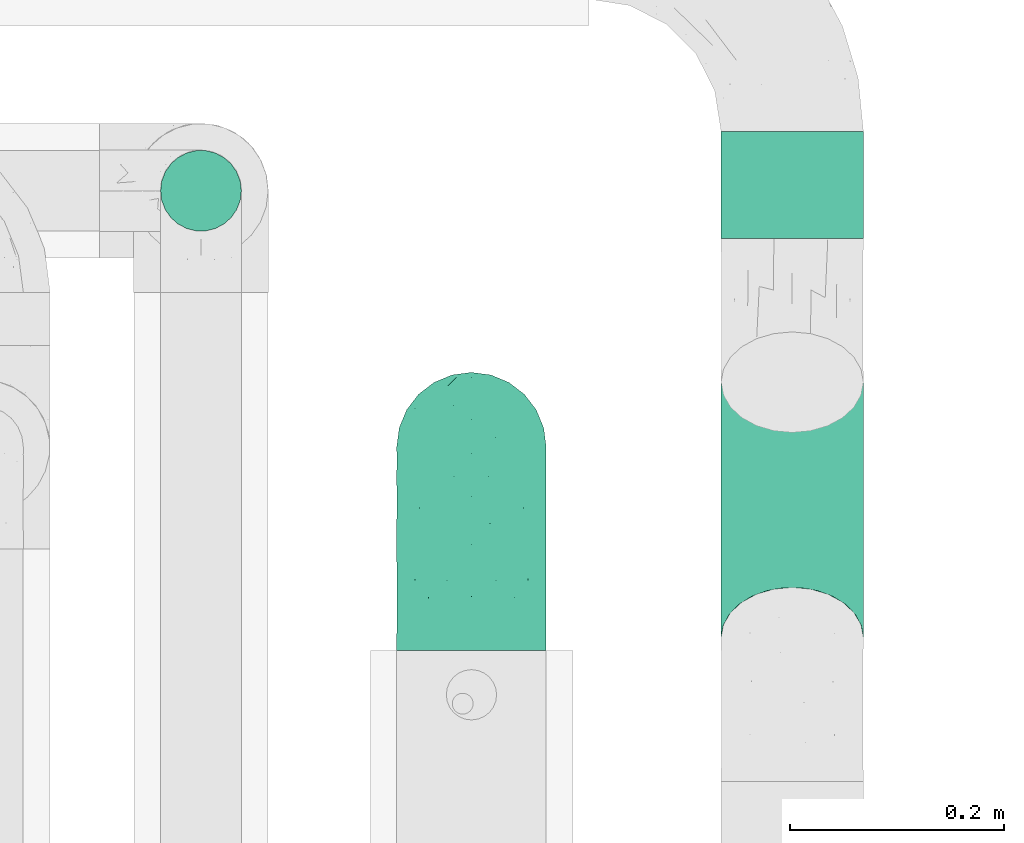
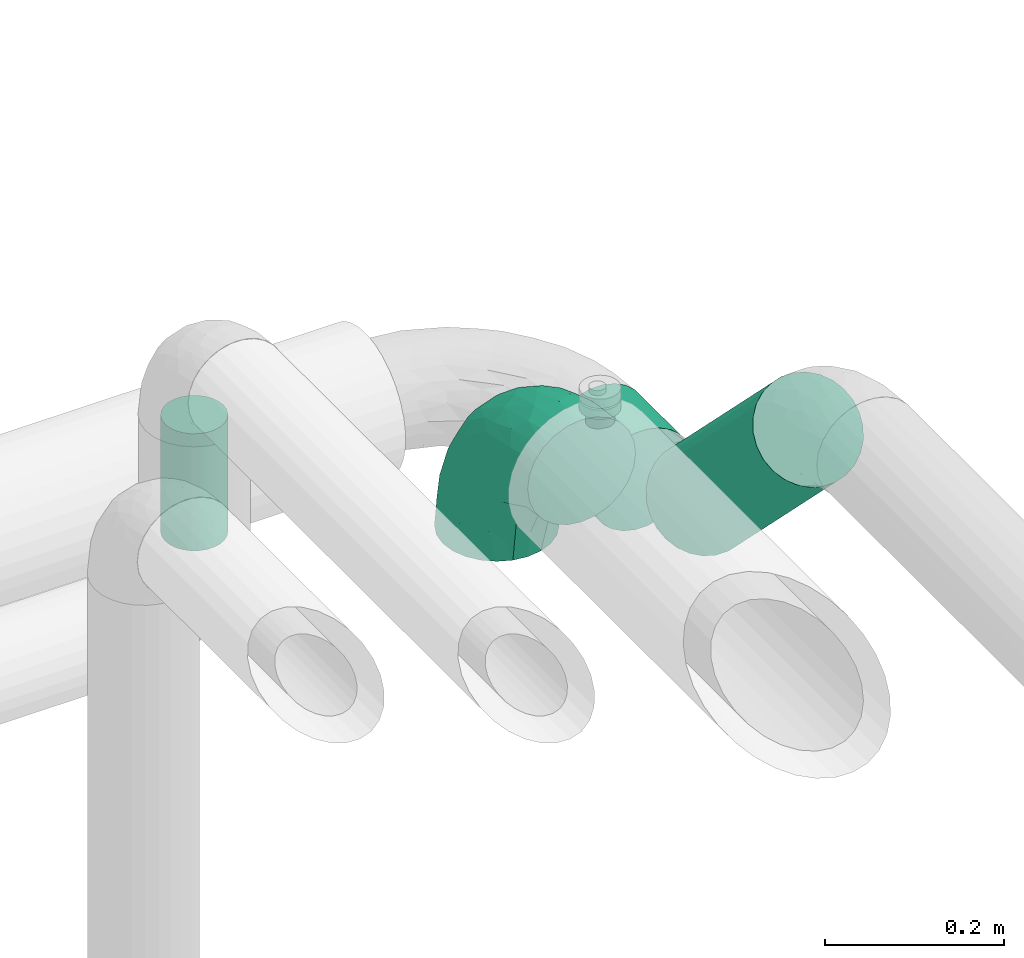
# One storey, part 558 of 824: 3 flow segments, 1 flow fitting.
"""IFC2X3 building model written with IfcOpenShell, lengths in millimetres."""

from ifc_helpers import new_model, entity, si_unit, converted_unit, derived_unit, direction, frame, origin, origin_2d_with_axis, place, context, subcontext, project, spatial, circle, extrude, faceted_brep, source, transform, mapped, material, type_object, type_shapes, element, save


model = new_model("IFC2X3")

# Units and contexts
model_context = context("Model", 3, precision=0.01, world=origin(), true_north=direction((6.12303176911189e-17, 1.0)))
body_context = subcontext(model_context, "Body", "Model", "MODEL_VIEW")
ifc_project = project(units=[si_unit("LENGTHUNIT", "METRE", prefix="MILLI"), si_unit("AREAUNIT", "SQUARE_METRE"), si_unit("VOLUMEUNIT", "CUBIC_METRE"), converted_unit("PLANEANGLEUNIT", "DEGREE", entity("IfcRatioMeasure", 0.0174532925199433), si_unit("PLANEANGLEUNIT", "RADIAN"), dimensions=[0, 0, 0, 0, 0, 0, 0]), si_unit("MASSUNIT", "GRAM", prefix="KILO"), derived_unit("MASSDENSITYUNIT", [(si_unit("MASSUNIT", "GRAM", prefix="KILO"), 1), (si_unit("LENGTHUNIT", "METRE"), -3)]), derived_unit("MOMENTOFINERTIAUNIT", [(si_unit("LENGTHUNIT", "METRE"), 4)]), si_unit("TIMEUNIT", "SECOND"), si_unit("FREQUENCYUNIT", "HERTZ"), si_unit("THERMODYNAMICTEMPERATUREUNIT", "DEGREE_CELSIUS"), derived_unit("THERMALTRANSMITTANCEUNIT", [(si_unit("MASSUNIT", "GRAM", prefix="KILO"), 1), (si_unit("THERMODYNAMICTEMPERATUREUNIT", "KELVIN"), -1), (si_unit("TIMEUNIT", "SECOND"), -3)]), derived_unit("VOLUMETRICFLOWRATEUNIT", [(si_unit("LENGTHUNIT", "METRE"), 3), (si_unit("TIMEUNIT", "SECOND"), -1)]), derived_unit("MASSFLOWRATEUNIT", [(si_unit("MASSUNIT", "GRAM", prefix="KILO"), 1), (si_unit("TIMEUNIT", "SECOND"), -1)]), derived_unit("ROTATIONALFREQUENCYUNIT", [(si_unit("TIMEUNIT", "SECOND"), -1)]), si_unit("ELECTRICCURRENTUNIT", "AMPERE"), si_unit("ELECTRICVOLTAGEUNIT", "VOLT"), si_unit("POWERUNIT", "WATT"), si_unit("FORCEUNIT", "NEWTON", prefix="KILO"), si_unit("ILLUMINANCEUNIT", "LUX"), si_unit("LUMINOUSFLUXUNIT", "LUMEN"), si_unit("LUMINOUSINTENSITYUNIT", "CANDELA"), derived_unit("USERDEFINED", [(si_unit("MASSUNIT", "GRAM", prefix="KILO"), -1), (si_unit("LENGTHUNIT", "METRE"), -2), (si_unit("TIMEUNIT", "SECOND"), 3), (si_unit("LUMINOUSFLUXUNIT", "LUMEN"), 1)]), derived_unit("LINEARVELOCITYUNIT", [(si_unit("LENGTHUNIT", "METRE"), 1), (si_unit("TIMEUNIT", "SECOND"), -1)]), si_unit("PRESSUREUNIT", "PASCAL"), derived_unit("USERDEFINED", [(si_unit("LENGTHUNIT", "METRE"), -2), (si_unit("MASSUNIT", "GRAM", prefix="KILO"), 1), (si_unit("TIMEUNIT", "SECOND"), -2)]), derived_unit("LINEARFORCEUNIT", [(si_unit("MASSUNIT", "GRAM", prefix="KILO"), 1), (si_unit("LENGTHUNIT", "METRE"), 1), (si_unit("TIMEUNIT", "SECOND"), -2), (si_unit("LENGTHUNIT", "METRE"), -1)]), derived_unit("PLANARFORCEUNIT", [(si_unit("MASSUNIT", "GRAM", prefix="KILO"), 1), (si_unit("LENGTHUNIT", "METRE"), 1), (si_unit("TIMEUNIT", "SECOND"), -2), (si_unit("LENGTHUNIT", "METRE"), -2)])], contexts=[model_context])

# Site, building, storey
site_placement = place(None, origin())
site = spatial("IfcSite", under=ifc_project, at=site_placement, CompositionType="ELEMENT")
building_placement = place(site_placement, origin())
building = spatial("IfcBuilding", under=site, at=building_placement, CompositionType="ELEMENT")
storey_placement = place(building_placement, frame((0.0, 0.0, 28200.0)))
storey = spatial("IfcBuildingStorey", under=building, at=storey_placement, CompositionType="ELEMENT", Elevation=28200.0)

# Flow segments
pipe_segment_type_1 = type_object("IfcPipeSegmentType", PredefinedType="NOTDEFINED")
flow_segment_1_placement = place(storey_placement, frame((27351.94, 12025.46, 3031.9)))
element("IfcFlowSegment", 1, at=flow_segment_1_placement, inside=storey, type_object=pipe_segment_type_1, context=body_context, shape_type="SweptSolid", body=[
    extrude(circle(Radius=66.5, at=origin_2d_with_axis()), frame((68.1, 0.0, 68.1), z_axis=(0.0, 1.0, 0.0), x_axis=(-1.0, 0.0, 0.0)), (0.0, 0.0, 1.0), 100.109244825128),
])
flow_segment_2_placement = place(storey_placement, frame((27351.94, 11603.79, 3107.03)))
element("IfcFlowSegment", 2, at=flow_segment_2_placement, inside=storey, type_object=pipe_segment_type_1, context=body_context, shape_type="SweptSolid", body=[
    extrude(circle(Radius=66.5, at=origin_2d_with_axis()), frame((68.1, 48.62, 287.32), z_axis=(0.0, 0.707106781186515, -0.70710678118658), x_axis=(-1.0, 0.0, 0.0)), (0.0, 0.0, 1.0), 337.573593128828),
])
pipe_segment_type_2 = type_object("IfcPipeSegmentType", PredefinedType="NOTDEFINED")
flow_segment_3_placement = place(storey_placement, frame((26828.29, 12030.66, 3195.0)))
element("IfcFlowSegment", 3, at=flow_segment_3_placement, inside=storey, type_object=pipe_segment_type_2, context=body_context, shape_type="SweptSolid", body=[
    extrude(circle(Radius=37.75, at=origin_2d_with_axis()), frame((39.35, 39.35, 0.0), z_axis=(0.0, 0.0, 1.0), x_axis=(-1.0, 0.0, 0.0)), (0.0, 0.0, 1.0), 160.000000000016),
])

# Flow fitting
ifc_material = material()
pipe_fitting_type = type_object("IfcPipeFittingType", PredefinedType="NOTDEFINED", material=ifc_material)
shared_shape = source(origin(), body_context, "Body", "Brep", [
    faceted_brep([(-190.0, 18.08, -67.47), (-190.0, 0.0, -69.85), (-190.0, -18.08, -67.47), (-190.0, -34.93, -60.49), (-190.0, -49.39, -49.39), (-190.0, -60.49, -34.93), (-190.0, -67.47, -18.08), (-190.0, -69.85, 0.0), (-190.0, -67.47, 18.08), (-190.0, -60.49, 34.92), (-190.0, -49.39, 49.39), (-190.0, -34.93, 60.49), (-190.0, -18.08, 67.47), (-190.0, 0.0, 69.85), (-190.0, 18.08, 67.47), (-190.0, 34.92, 60.49), (-190.0, 49.39, 49.39), (-190.0, 60.49, 34.92), (-190.0, 67.47, 18.08), (-190.0, 69.85, 0.0), (-190.0, 67.47, -18.08), (-190.0, 60.49, -34.93), (-190.0, 49.39, -49.39), (-190.0, 34.92, -60.49), (18.08, 190.0, -67.47), (0.0, 190.0, -69.85), (-18.08, 190.0, -67.47), (-34.92, 190.0, -60.49), (-49.39, 190.0, -49.39), (-60.49, 190.0, -34.93), (-67.47, 190.0, -18.08), (-69.85, 190.0, 0.0), (-67.47, 190.0, 18.08), (-60.49, 190.0, 34.92), (-49.39, 190.0, 49.39), (-34.92, 190.0, 60.49), (-18.08, 190.0, 67.47), (0.0, 190.0, 69.85), (18.08, 190.0, 67.47), (34.93, 190.0, 60.49), (49.39, 190.0, 49.39), (60.49, 190.0, 34.92), (67.47, 190.0, 18.08), (69.85, 190.0, 0.0), (67.47, 190.0, -18.08), (60.49, 190.0, -34.93), (49.39, 190.0, -49.39), (34.93, 190.0, -60.49), (-29.62, 146.98, 65.62), (-13.75, 135.37, 69.64), (-124.22, -36.33, 52.83), (-140.23, -52.18, 40.04), (-80.56, -34.09, 36.78), (-140.97, -24.01, 63.29), (-80.93, -8.05, 59.8), (-100.59, 5.62, 68.24), (-125.19, -57.65, 22.9), (-139.31, -64.86, 0.0), (-28.7, -8.91, 22.6), (-45.64, -26.06, 0.0), (-6.26, 6.26, 0.0), (-105.44, 36.89, 68.2), (-118.83, 43.56, 64.34), (-146.98, 29.62, 65.62), (-71.47, -38.86, 17.07), (-90.56, -50.07, 0.0), (-0.6, 27.02, 35.97), (-44.76, -2.31, 47.74), (-42.86, -12.1, 35.78), (-148.03, -7.38, 68.85), (-135.37, 13.75, 69.64), (-67.48, 159.11, 28.79), (36.32, 124.15, 52.82), (-38.8, 102.11, 68.2), (-24.59, 96.61, 69.85), (-81.73, 130.22, 21.92), (-65.15, 30.31, 68.68), (-27.72, 54.52, 66.49), (-44.98, 61.25, 69.74), (-75.73, 152.87, 0.0), (-159.11, 67.48, 28.79), (-130.22, 81.73, 21.92), (-152.87, 75.73, 0.0), (-76.65, 126.59, 35.57), (-101.51, 101.51, 25.92), (-96.74, 96.74, 38.75), (-144.94, 60.97, 45.11), (-159.57, 43.91, 56.71), (-119.38, 92.8, 0.0), (50.07, 90.56, 0.0), (57.42, 124.25, 22.84), (38.8, 71.6, 17.49), (64.86, 139.31, 0.0), (52.17, 140.21, 40.03), (33.37, 79.39, 36.99), (24.0, 140.95, 63.29), (8.03, 80.92, 59.81), (-82.61, -22.17, 50.94), (7.38, 148.03, 68.85), (-100.26, 79.14, 51.33), (-75.76, 96.1, 55.72), (-76.12, 111.95, 46.7), (-92.8, 119.38, 0.0), (-104.27, 104.27, 12.31), (10.07, 27.17, 16.15), (26.06, 45.64, 0.0), (-61.21, 144.14, 45.16), (-44.13, 158.15, 56.77), (-55.26, 120.41, 58.38), (9.95, 57.03, 48.64), (29.48, 90.08, 47.56), (-5.62, 100.59, 68.24), (-122.78, 54.24, 58.28), (-86.25, 73.26, 61.12), (-95.79, 24.47, 69.85), (-126.59, 76.65, 35.57), (-17.15, 26.56, 50.85), (-29.82, 29.82, 59.54), (-70.73, 11.02, 65.19), (-58.6, 94.58, 64.16), (-71.14, 66.1, 67.41), (-158.15, 44.13, -56.77), (33.37, 79.39, -36.99), (10.07, 27.17, -16.15), (-0.6, 27.02, -35.97), (-100.59, 5.62, -68.24), (-148.03, -7.38, -68.85), (-135.37, 13.75, -69.64), (-130.22, 81.73, -21.92), (-146.98, 29.62, -65.62), (-102.11, 38.8, -68.2), (-96.61, 24.59, -69.85), (-83.02, -24.86, -48.76), (-44.76, -2.31, -47.74), (-80.56, -34.09, -36.78), (-122.68, -57.24, -22.15), (-71.43, -38.87, -16.95), (-104.27, 104.27, -12.31), (-159.11, 67.48, -28.79), (-144.14, 61.21, -45.16), (7.38, 148.03, -68.85), (-13.75, 135.37, -69.64), (-79.14, 100.26, -51.33), (-96.1, 75.76, -55.72), (-111.95, 76.12, -46.7), (-80.93, -8.05, -59.8), (-124.22, -36.33, -52.83), (-140.23, -52.18, -40.04), (-24.47, 95.79, -69.85), (-36.89, 105.44, -68.2), (-150.18, -65.36, -13.92), (-43.56, 118.83, -64.34), (-29.62, 146.98, -65.62), (38.8, 71.6, -17.49), (-81.73, 130.22, -21.92), (-28.7, -8.91, -22.6), (-54.24, 122.78, -58.28), (-73.26, 86.25, -61.12), (-61.25, 44.98, -69.74), (-30.31, 65.15, -68.68), (-54.52, 27.72, -66.49), (-101.51, 101.51, -25.92), (-126.59, 76.65, -35.57), (-96.74, 96.74, -38.75), (-67.48, 159.11, -28.79), (-120.41, 55.26, -58.38), (-43.91, 159.57, -56.71), (24.0, 140.95, -63.29), (8.03, 80.92, -59.81), (-5.62, 100.59, -68.24), (-60.97, 144.94, -45.11), (36.32, 124.15, -52.82), (57.42, 124.25, -22.84), (52.17, 140.21, -40.03), (-140.97, -24.01, -63.29), (9.95, 57.03, -48.64), (-76.65, 126.59, -35.57), (22.84, 89.04, -52.94), (-11.03, 70.74, -65.2), (-29.82, 29.82, -59.54), (-94.58, 58.6, -64.16), (-66.1, 71.14, -67.41), (-31.42, -3.01, -36.09), (-13.88, 24.32, -46.86)], [[[0, 1, 2, 3, 4, 5, 6, 7, 8, 9, 10, 11, 12, 13, 14, 15, 16, 17, 18, 19, 20, 21, 22, 23]], [[24, 25, 26, 27, 28, 29, 30, 31, 32, 33, 34, 35, 36, 37, 38, 39, 40, 41, 42, 43, 44, 45, 46, 47]], [[36, 48, 49]], [[50, 51, 52]], [[53, 54, 55]], [[56, 9, 8]], [[8, 7, 57]], [[58, 59, 60]], [[51, 9, 56]], [[61, 62, 63]], [[59, 58, 64]], [[59, 64, 65]], [[11, 10, 50]], [[66, 67, 68]], [[50, 53, 11]], [[69, 70, 13]], [[71, 33, 32]], [[72, 40, 39]], [[73, 74, 49]], [[63, 15, 14]], [[13, 70, 14]], [[71, 32, 75]], [[12, 69, 13]], [[76, 77, 78]], [[32, 79, 75]], [[18, 80, 81]], [[63, 14, 70]], [[82, 19, 18]], [[83, 84, 85]], [[86, 16, 87]], [[82, 81, 88]], [[82, 18, 81]], [[15, 87, 16]], [[83, 71, 75]], [[52, 56, 64]], [[49, 37, 36]], [[89, 90, 91]], [[36, 35, 48]], [[42, 41, 90]], [[89, 92, 90]], [[11, 53, 12]], [[73, 78, 74]], [[65, 56, 57]], [[40, 72, 93]], [[94, 90, 93]], [[41, 40, 93]], [[72, 95, 96]], [[95, 39, 38]], [[8, 57, 56]], [[43, 42, 92]], [[67, 54, 97]], [[38, 37, 98]], [[99, 100, 101]], [[102, 75, 79]], [[51, 10, 9]], [[102, 88, 103]], [[31, 79, 32]], [[104, 60, 105]], [[106, 34, 33]], [[84, 103, 81]], [[91, 105, 89]], [[107, 35, 34]], [[106, 108, 107]], [[49, 48, 73]], [[104, 105, 91]], [[16, 86, 17]], [[58, 104, 66]], [[109, 110, 96]], [[111, 98, 49]], [[112, 113, 99]], [[92, 42, 90]], [[95, 72, 39]], [[70, 114, 61]], [[80, 18, 17]], [[101, 106, 83]], [[99, 86, 112]], [[115, 81, 80]], [[90, 94, 91]], [[94, 66, 104]], [[64, 58, 68]], [[56, 65, 64]], [[93, 72, 110]], [[90, 41, 93]], [[98, 95, 38]], [[111, 77, 96]], [[111, 96, 95]], [[67, 116, 117]], [[52, 51, 56]], [[50, 10, 51]], [[54, 53, 50]], [[69, 53, 55]], [[97, 52, 67]], [[118, 76, 55]], [[107, 48, 35]], [[73, 119, 120]], [[61, 63, 70]], [[63, 62, 87]], [[94, 104, 91]], [[58, 60, 104]], [[109, 66, 94]], [[67, 117, 54]], [[68, 67, 52]], [[116, 66, 109]], [[119, 48, 108]], [[73, 120, 78]], [[120, 61, 114]], [[78, 114, 76]], [[49, 98, 37]], [[95, 98, 111]], [[53, 69, 12]], [[70, 69, 55]], [[70, 55, 114]], [[120, 113, 62]], [[76, 114, 55]], [[120, 114, 78]], [[118, 55, 54]], [[76, 118, 77]], [[96, 77, 117]], [[111, 78, 77]], [[54, 117, 118]], [[77, 118, 117]], [[110, 109, 94]], [[116, 96, 117]], [[106, 107, 34]], [[48, 107, 108]], [[75, 84, 83]], [[106, 33, 71]], [[101, 83, 85]], [[106, 71, 83]], [[99, 101, 85]], [[108, 106, 101]], [[99, 85, 115]], [[113, 112, 62]], [[119, 113, 120]], [[100, 99, 113]], [[17, 86, 80]], [[115, 85, 84]], [[80, 86, 115]], [[99, 115, 86]], [[63, 87, 15]], [[86, 87, 112]], [[78, 111, 74]], [[111, 49, 74]], [[119, 100, 113]], [[101, 100, 108]], [[48, 119, 73]], [[119, 108, 100]], [[75, 102, 103]], [[115, 84, 81]], [[81, 103, 88]], [[75, 103, 84]], [[54, 50, 97]], [[52, 97, 50]], [[64, 68, 52]], [[66, 68, 58]], [[62, 61, 120]], [[87, 62, 112]], [[93, 110, 94]], [[96, 110, 72]], [[66, 116, 67]], [[96, 116, 109]], [[22, 121, 23]], [[122, 123, 124]], [[125, 126, 127]], [[20, 82, 128]], [[129, 130, 127]], [[130, 131, 127]], [[19, 82, 20]], [[132, 133, 134]], [[88, 128, 82]], [[135, 136, 65]], [[102, 137, 88]], [[138, 20, 128]], [[139, 22, 21]], [[140, 141, 25]], [[142, 143, 144]], [[145, 133, 132]], [[4, 146, 147]], [[141, 148, 149]], [[7, 6, 150]], [[138, 21, 20]], [[5, 4, 147]], [[149, 151, 152]], [[59, 65, 136]], [[122, 153, 123]], [[79, 30, 154]], [[134, 155, 136]], [[150, 65, 57]], [[156, 157, 142]], [[126, 2, 1]], [[134, 135, 147]], [[130, 158, 131]], [[159, 160, 158]], [[154, 161, 137]], [[0, 23, 129]], [[127, 1, 0]], [[162, 138, 128]], [[161, 163, 162]], [[30, 79, 31]], [[146, 4, 3]], [[154, 30, 164]], [[152, 27, 26]], [[165, 121, 139]], [[25, 24, 140]], [[25, 141, 26]], [[164, 30, 29]], [[27, 166, 28]], [[167, 168, 169]], [[141, 152, 26]], [[28, 170, 29]], [[47, 171, 167]], [[172, 89, 153]], [[59, 155, 60]], [[28, 166, 170]], [[46, 45, 173]], [[153, 89, 105]], [[105, 123, 153]], [[174, 146, 3]], [[171, 47, 46]], [[45, 44, 172]], [[7, 150, 57]], [[43, 92, 44]], [[122, 124, 175]], [[89, 172, 92]], [[171, 173, 122]], [[47, 167, 24]], [[173, 171, 46]], [[135, 150, 5]], [[0, 129, 127]], [[174, 3, 2]], [[79, 154, 102]], [[146, 174, 145]], [[44, 92, 172]], [[144, 139, 162]], [[142, 170, 156]], [[176, 154, 164]], [[105, 60, 123]], [[122, 172, 153]], [[45, 172, 173]], [[122, 173, 172]], [[167, 171, 177]], [[140, 167, 169]], [[177, 122, 175]], [[178, 159, 169]], [[134, 136, 135]], [[155, 59, 136]], [[134, 147, 146]], [[135, 5, 147]], [[126, 174, 2]], [[125, 160, 145]], [[125, 145, 174]], [[145, 179, 133]], [[121, 129, 23]], [[130, 180, 181]], [[149, 152, 141]], [[152, 151, 166]], [[60, 155, 123]], [[123, 155, 124]], [[182, 134, 133]], [[175, 179, 168]], [[183, 179, 175]], [[155, 182, 124]], [[180, 129, 165]], [[130, 181, 158]], [[181, 149, 148]], [[158, 148, 159]], [[127, 126, 1]], [[174, 126, 125]], [[167, 140, 24]], [[141, 140, 169]], [[141, 169, 148]], [[181, 157, 151]], [[159, 148, 169]], [[181, 148, 158]], [[178, 169, 168]], [[159, 178, 160]], [[145, 160, 179]], [[125, 158, 160]], [[168, 179, 178]], [[160, 178, 179]], [[175, 124, 183]], [[177, 175, 168]], [[139, 121, 22]], [[129, 121, 165]], [[128, 161, 162]], [[139, 21, 138]], [[144, 162, 163]], [[139, 138, 162]], [[142, 144, 163]], [[165, 139, 144]], [[142, 163, 176]], [[157, 156, 151]], [[180, 157, 181]], [[143, 142, 157]], [[29, 170, 164]], [[176, 163, 161]], [[164, 170, 176]], [[142, 176, 170]], [[152, 166, 27]], [[170, 166, 156]], [[158, 125, 131]], [[125, 127, 131]], [[180, 143, 157]], [[144, 143, 165]], [[129, 180, 130]], [[180, 165, 143]], [[128, 88, 137]], [[176, 161, 154]], [[154, 137, 102]], [[128, 137, 161]], [[5, 150, 6]], [[65, 150, 135]], [[134, 146, 132]], [[145, 132, 146]], [[134, 182, 155]], [[183, 182, 133]], [[151, 149, 181]], [[166, 151, 156]], [[182, 183, 124]], [[179, 183, 133]], [[167, 177, 168]], [[122, 177, 171]]]),
])
type_shapes(pipe_fitting_type, [shared_shape])
flow_fitting_placement = place(storey_placement, frame((27120.33, 11830.46, 3450.0), z_axis=(1.0, 0.0, 0.0), x_axis=(0.0, 0.0, 1.0)))
element("IfcFlowFitting", 4, at=flow_fitting_placement, inside=storey, type_object=pipe_fitting_type, material=ifc_material, context=body_context, shape_type="MappedRepresentation", body=[
    mapped(shared_shape, transform((0.0, 0.0, 0.0), scale=1.0)),
])

save(model, "model.ifc")
